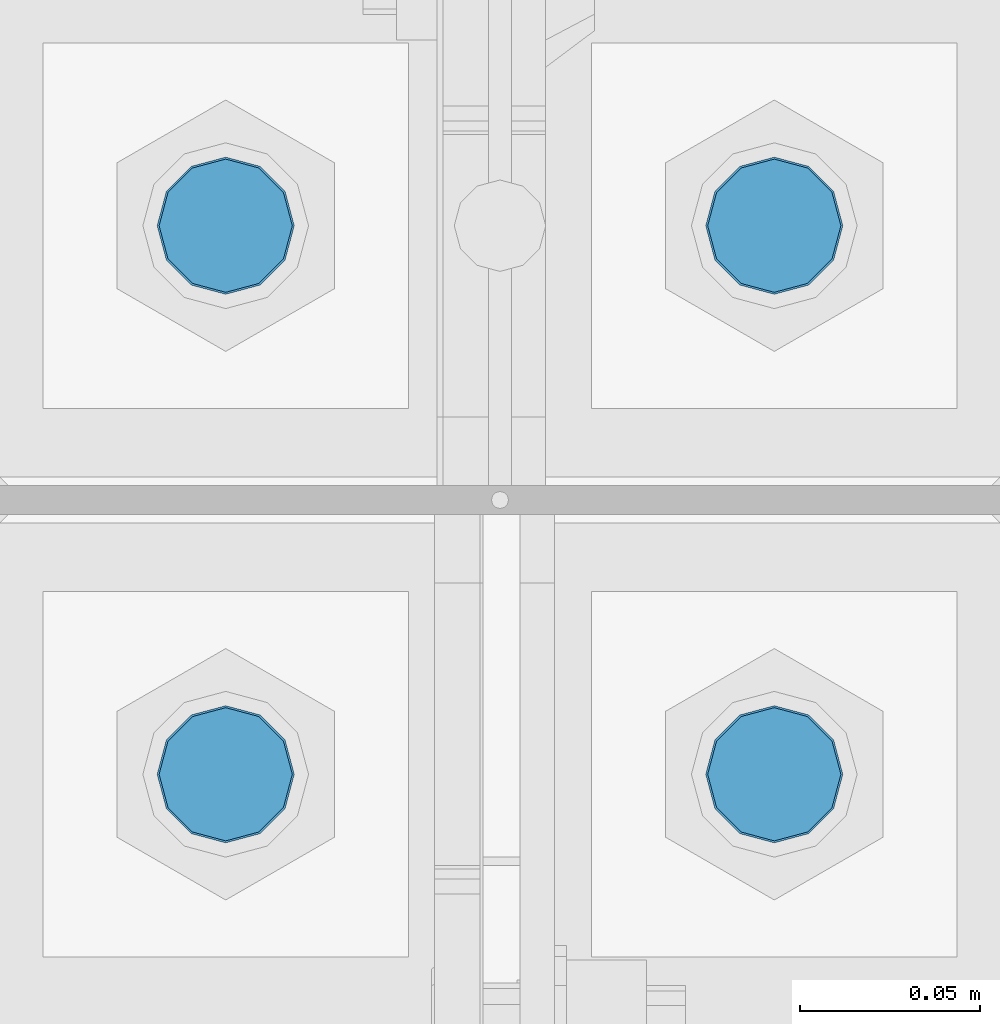
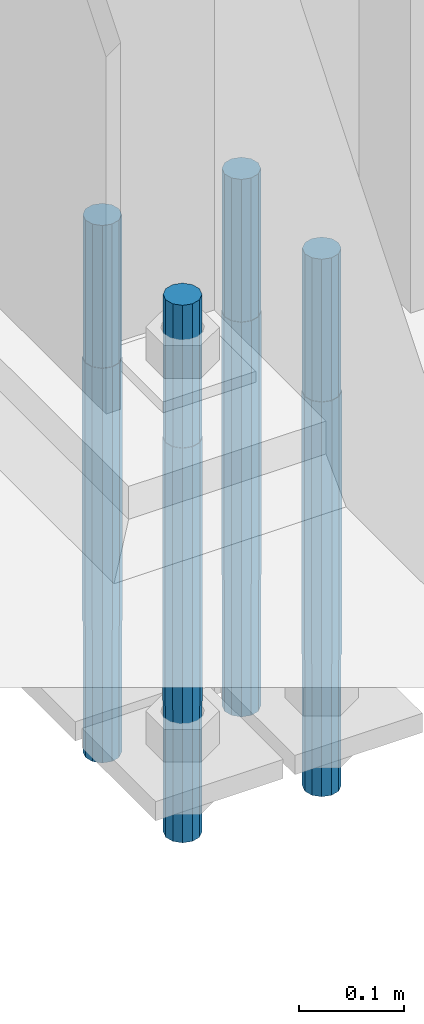
# One storey, part 1594 of 3843: 4 columns, 1 element without a shape of its own.
"""IFC2X3 building model written with IfcOpenShell, lengths in millimetres."""

from ifc_helpers import new_model, si_unit, frame, origin_with_axes, place, context, subcontext, project, spatial, faceted_brep, material, type_object, element, aggregate, save


model = new_model("IFC2X3")

# Units and contexts
model_context = context("Model", 3, precision=1e-05, world=origin_with_axes())
body_context = subcontext(model_context, "Body", "Model", "MODEL_VIEW")
ifc_project = project(units=[si_unit("LENGTHUNIT", "METRE", prefix="MILLI"), si_unit("AREAUNIT", "SQUARE_METRE"), si_unit("VOLUMEUNIT", "CUBIC_METRE"), si_unit("MASSUNIT", "GRAM", prefix="KILO"), si_unit("TIMEUNIT", "SECOND"), si_unit("PLANEANGLEUNIT", "RADIAN"), si_unit("SOLIDANGLEUNIT", "STERADIAN"), si_unit("THERMODYNAMICTEMPERATUREUNIT", "DEGREE_CELSIUS"), si_unit("LUMINOUSINTENSITYUNIT", "LUMEN")], contexts=[model_context])

# Site, building, storey
site_placement = place(None, origin_with_axes())
site = spatial("IfcSite", under=ifc_project, at=site_placement, CompositionType="ELEMENT")
building_placement = place(site_placement, origin_with_axes())
building = spatial("IfcBuilding", under=site, at=building_placement, Name="Undefined", CompositionType="ELEMENT")
storey_placement = place(building_placement, origin_with_axes())
storey = spatial("IfcBuildingStorey", under=building, at=storey_placement, Name="Undefined", CompositionType="ELEMENT", Elevation=0.0)

# Assembly, columns
assembly_placement = place(storey_placement, origin_with_axes())
assembly = element("IfcElementAssembly", 1, at=assembly_placement, inside=storey, Name="TEMPLATE", AssemblyPlace="NOTDEFINED", PredefinedType="RIGID_FRAME")
ifc_material = material(Name="Undefined/F1554-GR.55")
column_type = type_object("IfcColumnType", PredefinedType="NOTDEFINED")
column_1_placement = place(assembly_placement, frame((77089.0, 89039.7, 29565.6), z_axis=(1.0, 0.0, 0.0), x_axis=(0.0, 0.0, -1.0)))
column_1 = element("IfcColumn", 2, at=column_1_placement, type_object=column_type, material=ifc_material, Name="ANCHOR_ROD", context=body_context, shape_type="Brep", body=[
    faceted_brep([(-165.100000000002, -16.0214699700118, 9.25), (-165.100000000002, -9.25, 16.0214699700155), (-165.100000000002, 0.0, 18.5), (-165.100000000002, 9.25, 16.0214699700155), (-165.100000000002, 16.0214699700118, 9.25), (-165.100000000002, 18.5, 0.0), (-165.100000000002, 16.0214699700118, -9.25), (-165.100000000002, 9.25, -16.0214699700155), (-165.100000000002, 0.0, -18.5), (-165.100000000002, -9.25, -16.0214699700155), (-165.100000000002, -16.0214699700118, -9.25), (-165.100000000002, -18.5, 0.0), (0.0, 18.5, 0.0), (0.0, 16.0214699700118, -9.25), (0.0, 9.25, -16.0214699700155), (0.0, 0.0, -18.5), (0.0, -9.25, -16.0214699700155), (0.0, -16.0214699700118, -9.25), (0.0, -18.5, 0.0), (0.0, -16.0214699700118, 9.25), (0.0, -9.25, 16.0214699700155), (0.0, 0.0, 18.5), (0.0, 9.25, 16.0214699700155), (0.0, 16.0214699700118, 9.25), (0.0, -16.4977839420972, 9.52500000000146), (0.0, -9.52500000000146, 16.4977839420972), (0.0, 0.0, 19.0499989999989), (0.0, 9.52500000000146, 16.4977839420972), (0.0, 16.4977839420972, 9.52500000000146), (0.0, 19.0500000000029, 0.0), (0.0, 16.4977839420972, -9.52500000000146), (0.0, 9.52500000000146, -16.4977839420972), (0.0, 0.0, -19.0499989999989), (0.0, -9.52500000000146, -16.4977839420972), (0.0, -16.4977839420972, -9.52500000000146), (0.0, -19.0500000000029, 0.0), (304.799999999999, -19.0499999999993, 0.0), (304.799999999999, -16.4977839420935, 9.52499999999418), (304.799999999999, -9.52500000000146, 16.4977839420899), (304.799987999999, 0.0, 19.0499989999989), (304.799999999999, 9.52500000000146, 16.4977839420899), (304.799999999999, 16.4977839420935, 9.52499999999418), (304.799987792969, 19.0499999999993, 0.0), (304.799999999999, 16.4977839420935, -9.52499999999418), (304.799999999999, 9.52500000000146, -16.4977839420899), (304.799987999999, 0.0, -19.0499989999989), (304.799999999999, -9.52500000000146, -16.4977839420899), (304.799999999999, -16.4977839420935, -9.52499999999418), (304.799999999999, -9.25, 16.0214699700155), (304.799999999999, 0.0, 18.5), (304.799999999999, 9.25, 16.0214699700155), (304.799999999999, 16.0214699700118, 9.25), (304.799999999999, 18.5, 0.0), (304.799999999999, 16.0214699700118, -9.25), (304.799999999999, 9.25, -16.0214699700155), (304.799999999999, 0.0, -18.5), (304.799999999999, -9.25, -16.0214699700155), (304.799999999999, -16.0214699700118, -9.25), (304.799999999999, -18.5, 0.0), (304.799999999999, -16.0214699700118, 9.25), (457.200000000001, -9.25, -16.0214699700155), (457.200000000001, 0.0, -18.5), (457.200000000001, 9.25, -16.0214699700155), (457.200000000001, 16.0214699700118, -9.25), (457.200000000001, 18.5, 0.0), (457.200000000001, 16.0214699700118, 9.25), (457.200000000001, 9.25, 16.0214699700155), (457.200000000001, 0.0, 18.5), (457.200000000001, -9.25, 16.0214699700155), (457.200000000001, -16.0214699700118, 9.25), (457.200000000001, -18.5, 0.0), (457.200000000001, -16.0214699700118, -9.25)], [[[0, 1, 2, 3, 4, 5, 6, 7, 8, 9, 10, 11]], [[6, 5, 12, 13]], [[7, 6, 13, 14]], [[8, 7, 14, 15]], [[9, 8, 15, 16]], [[10, 9, 16, 17]], [[11, 10, 17, 18]], [[0, 11, 18, 19]], [[1, 0, 19, 20]], [[2, 1, 20, 21]], [[3, 2, 21, 22]], [[4, 3, 22, 23]], [[5, 4, 23, 12]], [[24, 25, 26, 27, 28, 29, 30, 31, 32, 33, 34, 35], [22, 21, 20, 19, 18, 17, 16, 15, 14, 13, 12, 23]], [[24, 35, 36, 37]], [[25, 24, 37, 38]], [[26, 25, 38, 39]], [[27, 26, 39, 40]], [[28, 27, 40, 41]], [[29, 28, 41, 42]], [[30, 29, 42, 43]], [[31, 30, 43, 44]], [[32, 31, 44, 45]], [[33, 32, 45, 46]], [[34, 33, 46, 47]], [[35, 34, 47, 36]], [[46, 45, 44, 43, 42, 41, 40, 39, 38, 37, 36, 47], [48, 49, 50, 51, 52, 53, 54, 55, 56, 57, 58, 59]], [[60, 61, 62, 63, 64, 65, 66, 67, 68, 69, 70, 71]], [[68, 67, 49, 48]], [[69, 68, 48, 59]], [[70, 69, 59, 58]], [[71, 70, 58, 57]], [[60, 71, 57, 56]], [[61, 60, 56, 55]], [[62, 61, 55, 54]], [[63, 62, 54, 53]], [[64, 63, 53, 52]], [[65, 64, 52, 51]], [[66, 65, 51, 50]], [[67, 66, 50, 49]]]),
])
column_2_placement = place(assembly_placement, frame((77089.0, 89192.1, 29565.6), z_axis=(-1.0, 0.0, 0.0), x_axis=(0.0, 0.0, -1.0)))
column_2 = element("IfcColumn", 3, at=column_2_placement, type_object=column_type, material=ifc_material, Name="ANCHOR_ROD", context=body_context, shape_type="Brep", body=[
    faceted_brep([(-165.100000000002, -16.0214699700118, 9.25), (-165.100000000002, -9.25, 16.0214699700155), (-165.100000000002, 0.0, 18.5), (-165.100000000002, 9.25, 16.0214699700155), (-165.100000000002, 16.0214699700118, 9.25), (-165.100000000002, 18.5, 0.0), (-165.100000000002, 16.0214699700118, -9.25), (-165.100000000002, 9.25, -16.0214699700155), (-165.100000000002, 0.0, -18.5), (-165.100000000002, -9.25, -16.0214699700155), (-165.100000000002, -16.0214699700118, -9.25), (-165.100000000002, -18.5, 0.0), (0.0, 18.5, 0.0), (0.0, 16.0214699700118, -9.25), (0.0, 9.25, -16.0214699700155), (0.0, 0.0, -18.5), (0.0, -9.25, -16.0214699700155), (0.0, -16.0214699700118, -9.25), (0.0, -18.5, 0.0), (0.0, -16.0214699700118, 9.25), (0.0, -9.25, 16.0214699700155), (0.0, 0.0, 18.5), (0.0, 9.25, 16.0214699700155), (0.0, 16.0214699700118, 9.25), (0.0, -16.4977839420972, 9.52500000000146), (0.0, -9.52500000000146, 16.4977839420972), (0.0, 0.0, 19.0499989999989), (0.0, 9.52500000000146, 16.4977839420972), (0.0, 16.4977839420972, 9.52500000000146), (0.0, 19.0500000000029, 0.0), (0.0, 16.4977839420972, -9.52500000000146), (0.0, 9.52500000000146, -16.4977839420972), (0.0, 0.0, -19.0499989999989), (0.0, -9.52500000000146, -16.4977839420972), (0.0, -16.4977839420972, -9.52500000000146), (0.0, -19.0500000000029, 0.0), (304.799999999999, -19.0499999999993, 0.0), (304.799999999999, -16.4977839420935, 9.52499999999418), (304.799999999999, -9.52500000000146, 16.4977839420899), (304.799987999999, 0.0, 19.0499989999989), (304.799999999999, 9.52500000000146, 16.4977839420899), (304.799999999999, 16.4977839420935, 9.52499999999418), (304.799987792969, 19.0499999999993, 0.0), (304.799999999999, 16.4977839420935, -9.52499999999418), (304.799999999999, 9.52500000000146, -16.4977839420899), (304.799987999999, 0.0, -19.0499989999989), (304.799999999999, -9.52500000000146, -16.4977839420899), (304.799999999999, -16.4977839420935, -9.52499999999418), (304.799999999999, -9.25, 16.0214699700155), (304.799999999999, 0.0, 18.5), (304.799999999999, 9.25, 16.0214699700155), (304.799999999999, 16.0214699700118, 9.25), (304.799999999999, 18.5, 0.0), (304.799999999999, 16.0214699700118, -9.25), (304.799999999999, 9.25, -16.0214699700155), (304.799999999999, 0.0, -18.5), (304.799999999999, -9.25, -16.0214699700155), (304.799999999999, -16.0214699700118, -9.25), (304.799999999999, -18.5, 0.0), (304.799999999999, -16.0214699700118, 9.25), (457.200000000001, -9.25, -16.0214699700155), (457.200000000001, 0.0, -18.5), (457.200000000001, 9.25, -16.0214699700155), (457.200000000001, 16.0214699700118, -9.25), (457.200000000001, 18.5, 0.0), (457.200000000001, 16.0214699700118, 9.25), (457.200000000001, 9.25, 16.0214699700155), (457.200000000001, 0.0, 18.5), (457.200000000001, -9.25, 16.0214699700155), (457.200000000001, -16.0214699700118, 9.25), (457.200000000001, -18.5, 0.0), (457.200000000001, -16.0214699700118, -9.25)], [[[0, 1, 2, 3, 4, 5, 6, 7, 8, 9, 10, 11]], [[6, 5, 12, 13]], [[7, 6, 13, 14]], [[8, 7, 14, 15]], [[9, 8, 15, 16]], [[10, 9, 16, 17]], [[11, 10, 17, 18]], [[0, 11, 18, 19]], [[1, 0, 19, 20]], [[2, 1, 20, 21]], [[3, 2, 21, 22]], [[4, 3, 22, 23]], [[5, 4, 23, 12]], [[24, 25, 26, 27, 28, 29, 30, 31, 32, 33, 34, 35], [22, 21, 20, 19, 18, 17, 16, 15, 14, 13, 12, 23]], [[24, 35, 36, 37]], [[25, 24, 37, 38]], [[26, 25, 38, 39]], [[27, 26, 39, 40]], [[28, 27, 40, 41]], [[29, 28, 41, 42]], [[30, 29, 42, 43]], [[31, 30, 43, 44]], [[32, 31, 44, 45]], [[33, 32, 45, 46]], [[34, 33, 46, 47]], [[35, 34, 47, 36]], [[46, 45, 44, 43, 42, 41, 40, 39, 38, 37, 36, 47], [48, 49, 50, 51, 52, 53, 54, 55, 56, 57, 58, 59]], [[60, 61, 62, 63, 64, 65, 66, 67, 68, 69, 70, 71]], [[68, 67, 49, 48]], [[69, 68, 48, 59]], [[70, 69, 59, 58]], [[71, 70, 58, 57]], [[60, 71, 57, 56]], [[61, 60, 56, 55]], [[62, 61, 55, 54]], [[63, 62, 54, 53]], [[64, 63, 53, 52]], [[65, 64, 52, 51]], [[66, 65, 51, 50]], [[67, 66, 50, 49]]]),
])
column_3_placement = place(assembly_placement, frame((76936.6, 89039.7, 29565.6), z_axis=(1.0, 0.0, 0.0), x_axis=(0.0, 0.0, -1.0)))
column_3 = element("IfcColumn", 4, at=column_3_placement, type_object=column_type, material=ifc_material, Name="ANCHOR_ROD", context=body_context, shape_type="Brep", body=[
    faceted_brep([(-165.100000000002, -16.0214699700118, 9.25), (-165.100000000002, -9.25, 16.0214699700155), (-165.100000000002, 0.0, 18.5), (-165.100000000002, 9.25, 16.0214699700155), (-165.100000000002, 16.0214699700118, 9.25), (-165.100000000002, 18.5, 0.0), (-165.100000000002, 16.0214699700118, -9.25), (-165.100000000002, 9.25, -16.0214699700155), (-165.100000000002, 0.0, -18.5), (-165.100000000002, -9.25, -16.0214699700155), (-165.100000000002, -16.0214699700118, -9.25), (-165.100000000002, -18.5, 0.0), (0.0, 18.5, 0.0), (0.0, 16.0214699700118, -9.25), (0.0, 9.25, -16.0214699700155), (0.0, 0.0, -18.5), (0.0, -9.25, -16.0214699700155), (0.0, -16.0214699700118, -9.25), (0.0, -18.5, 0.0), (0.0, -16.0214699700118, 9.25), (0.0, -9.25, 16.0214699700155), (0.0, 0.0, 18.5), (0.0, 9.25, 16.0214699700155), (0.0, 16.0214699700118, 9.25), (0.0, -16.4977839420972, 9.52500000000146), (0.0, -9.52500000000146, 16.4977839420972), (0.0, 0.0, 19.0499989999989), (0.0, 9.52500000000146, 16.4977839420972), (0.0, 16.4977839420972, 9.52500000000146), (0.0, 19.0500000000029, 0.0), (0.0, 16.4977839420972, -9.52500000000146), (0.0, 9.52500000000146, -16.4977839420972), (0.0, 0.0, -19.0499989999989), (0.0, -9.52500000000146, -16.4977839420972), (0.0, -16.4977839420972, -9.52500000000146), (0.0, -19.0500000000029, 0.0), (304.799999999999, -19.0499999999993, 0.0), (304.799999999999, -16.4977839420935, 9.52499999999418), (304.799999999999, -9.52500000000146, 16.4977839420899), (304.799987999999, 0.0, 19.0499989999989), (304.799999999999, 9.52500000000146, 16.4977839420899), (304.799999999999, 16.4977839420935, 9.52499999999418), (304.799987792969, 19.0499999999993, 0.0), (304.799999999999, 16.4977839420935, -9.52499999999418), (304.799999999999, 9.52500000000146, -16.4977839420899), (304.799987999999, 0.0, -19.0499989999989), (304.799999999999, -9.52500000000146, -16.4977839420899), (304.799999999999, -16.4977839420935, -9.52499999999418), (304.799999999999, -9.25, 16.0214699700155), (304.799999999999, 0.0, 18.5), (304.799999999999, 9.25, 16.0214699700155), (304.799999999999, 16.0214699700118, 9.25), (304.799999999999, 18.5, 0.0), (304.799999999999, 16.0214699700118, -9.25), (304.799999999999, 9.25, -16.0214699700155), (304.799999999999, 0.0, -18.5), (304.799999999999, -9.25, -16.0214699700155), (304.799999999999, -16.0214699700118, -9.25), (304.799999999999, -18.5, 0.0), (304.799999999999, -16.0214699700118, 9.25), (457.200000000001, -9.25, -16.0214699700155), (457.200000000001, 0.0, -18.5), (457.200000000001, 9.25, -16.0214699700155), (457.200000000001, 16.0214699700118, -9.25), (457.200000000001, 18.5, 0.0), (457.200000000001, 16.0214699700118, 9.25), (457.200000000001, 9.25, 16.0214699700155), (457.200000000001, 0.0, 18.5), (457.200000000001, -9.25, 16.0214699700155), (457.200000000001, -16.0214699700118, 9.25), (457.200000000001, -18.5, 0.0), (457.200000000001, -16.0214699700118, -9.25)], [[[0, 1, 2, 3, 4, 5, 6, 7, 8, 9, 10, 11]], [[6, 5, 12, 13]], [[7, 6, 13, 14]], [[8, 7, 14, 15]], [[9, 8, 15, 16]], [[10, 9, 16, 17]], [[11, 10, 17, 18]], [[0, 11, 18, 19]], [[1, 0, 19, 20]], [[2, 1, 20, 21]], [[3, 2, 21, 22]], [[4, 3, 22, 23]], [[5, 4, 23, 12]], [[24, 25, 26, 27, 28, 29, 30, 31, 32, 33, 34, 35], [22, 21, 20, 19, 18, 17, 16, 15, 14, 13, 12, 23]], [[24, 35, 36, 37]], [[25, 24, 37, 38]], [[26, 25, 38, 39]], [[27, 26, 39, 40]], [[28, 27, 40, 41]], [[29, 28, 41, 42]], [[30, 29, 42, 43]], [[31, 30, 43, 44]], [[32, 31, 44, 45]], [[33, 32, 45, 46]], [[34, 33, 46, 47]], [[35, 34, 47, 36]], [[46, 45, 44, 43, 42, 41, 40, 39, 38, 37, 36, 47], [48, 49, 50, 51, 52, 53, 54, 55, 56, 57, 58, 59]], [[60, 61, 62, 63, 64, 65, 66, 67, 68, 69, 70, 71]], [[68, 67, 49, 48]], [[69, 68, 48, 59]], [[70, 69, 59, 58]], [[71, 70, 58, 57]], [[60, 71, 57, 56]], [[61, 60, 56, 55]], [[62, 61, 55, 54]], [[63, 62, 54, 53]], [[64, 63, 53, 52]], [[65, 64, 52, 51]], [[66, 65, 51, 50]], [[67, 66, 50, 49]]]),
])
column_4_placement = place(assembly_placement, frame((76936.6, 89192.1, 29565.6), z_axis=(-1.0, 0.0, 0.0), x_axis=(0.0, 0.0, -1.0)))
column_4 = element("IfcColumn", 5, at=column_4_placement, type_object=column_type, material=ifc_material, Name="ANCHOR_ROD", context=body_context, shape_type="Brep", body=[
    faceted_brep([(-165.100000000002, -16.0214699700118, 9.25), (-165.100000000002, -9.25, 16.0214699700155), (-165.100000000002, 0.0, 18.5), (-165.100000000002, 9.25, 16.0214699700155), (-165.100000000002, 16.0214699700118, 9.25), (-165.100000000002, 18.5, 0.0), (-165.100000000002, 16.0214699700118, -9.25), (-165.100000000002, 9.25, -16.0214699700155), (-165.100000000002, 0.0, -18.5), (-165.100000000002, -9.25, -16.0214699700155), (-165.100000000002, -16.0214699700118, -9.25), (-165.100000000002, -18.5, 0.0), (0.0, 18.5, 0.0), (0.0, 16.0214699700118, -9.25), (0.0, 9.25, -16.0214699700155), (0.0, 0.0, -18.5), (0.0, -9.25, -16.0214699700155), (0.0, -16.0214699700118, -9.25), (0.0, -18.5, 0.0), (0.0, -16.0214699700118, 9.25), (0.0, -9.25, 16.0214699700155), (0.0, 0.0, 18.5), (0.0, 9.25, 16.0214699700155), (0.0, 16.0214699700118, 9.25), (0.0, -16.4977839420972, 9.52500000000146), (0.0, -9.52500000000146, 16.4977839420972), (0.0, 0.0, 19.0499989999989), (0.0, 9.52500000000146, 16.4977839420972), (0.0, 16.4977839420972, 9.52500000000146), (0.0, 19.0500000000029, 0.0), (0.0, 16.4977839420972, -9.52500000000146), (0.0, 9.52500000000146, -16.4977839420972), (0.0, 0.0, -19.0499989999989), (0.0, -9.52500000000146, -16.4977839420972), (0.0, -16.4977839420972, -9.52500000000146), (0.0, -19.0500000000029, 0.0), (304.799999999999, -19.0499999999993, 0.0), (304.799999999999, -16.4977839420935, 9.52499999999418), (304.799999999999, -9.52500000000146, 16.4977839420899), (304.799987999999, 0.0, 19.0499989999989), (304.799999999999, 9.52500000000146, 16.4977839420899), (304.799999999999, 16.4977839420935, 9.52499999999418), (304.799987792969, 19.0499999999993, 0.0), (304.799999999999, 16.4977839420935, -9.52499999999418), (304.799999999999, 9.52500000000146, -16.4977839420899), (304.799987999999, 0.0, -19.0499989999989), (304.799999999999, -9.52500000000146, -16.4977839420899), (304.799999999999, -16.4977839420935, -9.52499999999418), (304.799999999999, -9.25, 16.0214699700155), (304.799999999999, 0.0, 18.5), (304.799999999999, 9.25, 16.0214699700155), (304.799999999999, 16.0214699700118, 9.25), (304.799999999999, 18.5, 0.0), (304.799999999999, 16.0214699700118, -9.25), (304.799999999999, 9.25, -16.0214699700155), (304.799999999999, 0.0, -18.5), (304.799999999999, -9.25, -16.0214699700155), (304.799999999999, -16.0214699700118, -9.25), (304.799999999999, -18.5, 0.0), (304.799999999999, -16.0214699700118, 9.25), (457.200000000001, -9.25, -16.0214699700155), (457.200000000001, 0.0, -18.5), (457.200000000001, 9.25, -16.0214699700155), (457.200000000001, 16.0214699700118, -9.25), (457.200000000001, 18.5, 0.0), (457.200000000001, 16.0214699700118, 9.25), (457.200000000001, 9.25, 16.0214699700155), (457.200000000001, 0.0, 18.5), (457.200000000001, -9.25, 16.0214699700155), (457.200000000001, -16.0214699700118, 9.25), (457.200000000001, -18.5, 0.0), (457.200000000001, -16.0214699700118, -9.25)], [[[0, 1, 2, 3, 4, 5, 6, 7, 8, 9, 10, 11]], [[6, 5, 12, 13]], [[7, 6, 13, 14]], [[8, 7, 14, 15]], [[9, 8, 15, 16]], [[10, 9, 16, 17]], [[11, 10, 17, 18]], [[0, 11, 18, 19]], [[1, 0, 19, 20]], [[2, 1, 20, 21]], [[3, 2, 21, 22]], [[4, 3, 22, 23]], [[5, 4, 23, 12]], [[24, 25, 26, 27, 28, 29, 30, 31, 32, 33, 34, 35], [22, 21, 20, 19, 18, 17, 16, 15, 14, 13, 12, 23]], [[24, 35, 36, 37]], [[25, 24, 37, 38]], [[26, 25, 38, 39]], [[27, 26, 39, 40]], [[28, 27, 40, 41]], [[29, 28, 41, 42]], [[30, 29, 42, 43]], [[31, 30, 43, 44]], [[32, 31, 44, 45]], [[33, 32, 45, 46]], [[34, 33, 46, 47]], [[35, 34, 47, 36]], [[46, 45, 44, 43, 42, 41, 40, 39, 38, 37, 36, 47], [48, 49, 50, 51, 52, 53, 54, 55, 56, 57, 58, 59]], [[60, 61, 62, 63, 64, 65, 66, 67, 68, 69, 70, 71]], [[68, 67, 49, 48]], [[69, 68, 48, 59]], [[70, 69, 59, 58]], [[71, 70, 58, 57]], [[60, 71, 57, 56]], [[61, 60, 56, 55]], [[62, 61, 55, 54]], [[63, 62, 54, 53]], [[64, 63, 53, 52]], [[65, 64, 52, 51]], [[66, 65, 51, 50]], [[67, 66, 50, 49]]]),
])
aggregate(assembly, [column_1, column_2, column_3, column_4])

save(model, "model.ifc")
